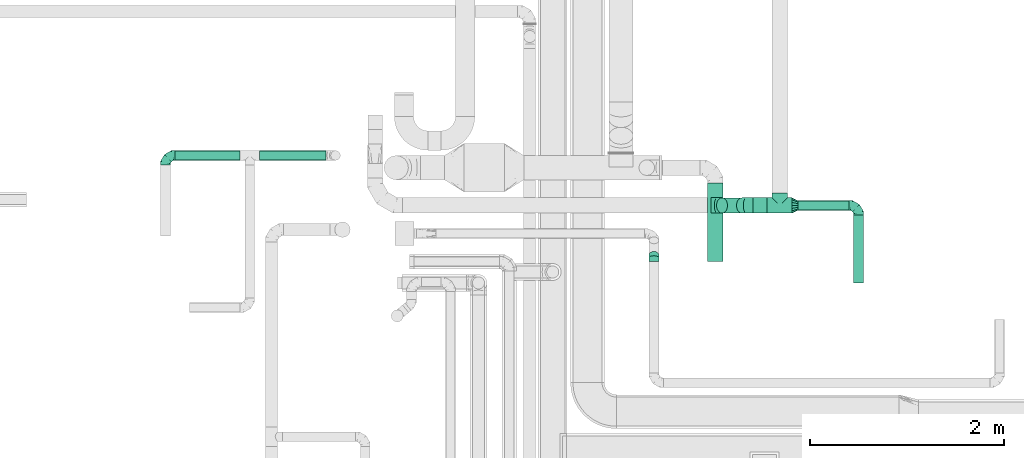
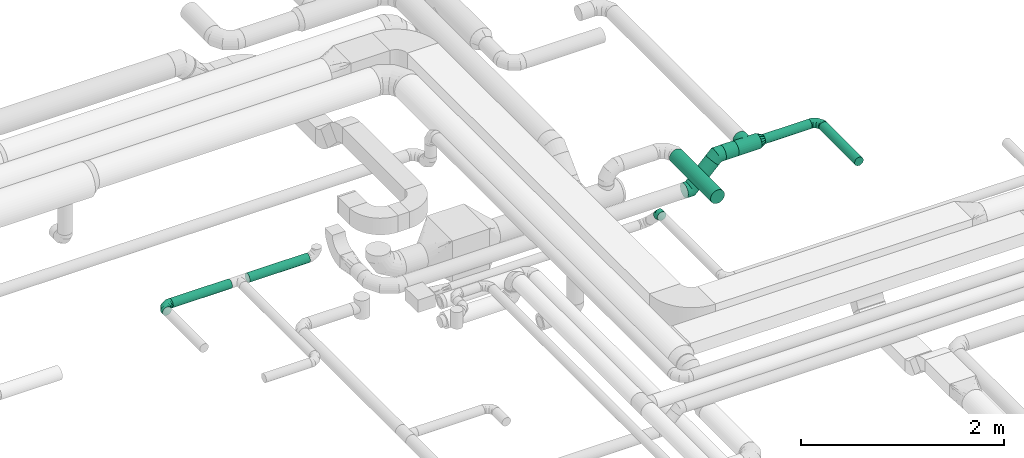
# One storey, part 69 of 92: 7 flow fittings, 7 flow segments.
"""IFC2X3 building model written with IfcOpenShell, lengths in millimetres."""

from ifc_helpers import new_model, entity, si_unit, converted_unit, derived_unit, direction, frame, origin, origin_2d_with_axis, place, context, subcontext, project, spatial, circle, extrude, faceted_brep, source, transform, mapped, material, type_object, type_shapes, element, save


model = new_model("IFC2X3")

# Units and contexts
model_context = context("Model", 3, precision=0.01, world=origin(), true_north=direction((6.12303176911189e-17, 1.0)))
body_context = subcontext(model_context, "Body", "Model", "MODEL_VIEW")
ifc_project = project(units=[si_unit("LENGTHUNIT", "METRE", prefix="MILLI"), si_unit("AREAUNIT", "SQUARE_METRE"), si_unit("VOLUMEUNIT", "CUBIC_METRE"), converted_unit("PLANEANGLEUNIT", "DEGREE", entity("IfcRatioMeasure", 0.0174532925199433), si_unit("PLANEANGLEUNIT", "RADIAN"), dimensions=[0, 0, 0, 0, 0, 0, 0]), si_unit("MASSUNIT", "GRAM", prefix="KILO"), derived_unit("MASSDENSITYUNIT", [(si_unit("MASSUNIT", "GRAM", prefix="KILO"), 1), (si_unit("LENGTHUNIT", "METRE"), -3)]), derived_unit("MOMENTOFINERTIAUNIT", [(si_unit("LENGTHUNIT", "METRE"), 4)]), si_unit("TIMEUNIT", "SECOND"), si_unit("FREQUENCYUNIT", "HERTZ"), si_unit("THERMODYNAMICTEMPERATUREUNIT", "DEGREE_CELSIUS"), derived_unit("THERMALTRANSMITTANCEUNIT", [(si_unit("MASSUNIT", "GRAM", prefix="KILO"), 1), (si_unit("THERMODYNAMICTEMPERATUREUNIT", "KELVIN"), -1), (si_unit("TIMEUNIT", "SECOND"), -3)]), derived_unit("VOLUMETRICFLOWRATEUNIT", [(si_unit("LENGTHUNIT", "METRE"), 3), (si_unit("TIMEUNIT", "SECOND"), -1)]), derived_unit("MASSFLOWRATEUNIT", [(si_unit("MASSUNIT", "GRAM", prefix="KILO"), 1), (si_unit("TIMEUNIT", "SECOND"), -1)]), derived_unit("ROTATIONALFREQUENCYUNIT", [(si_unit("TIMEUNIT", "SECOND"), -1)]), si_unit("ELECTRICCURRENTUNIT", "AMPERE"), si_unit("ELECTRICVOLTAGEUNIT", "VOLT"), si_unit("POWERUNIT", "WATT"), si_unit("FORCEUNIT", "NEWTON", prefix="KILO"), si_unit("ILLUMINANCEUNIT", "LUX"), si_unit("LUMINOUSFLUXUNIT", "LUMEN"), si_unit("LUMINOUSINTENSITYUNIT", "CANDELA"), derived_unit("USERDEFINED", [(si_unit("MASSUNIT", "GRAM", prefix="KILO"), -1), (si_unit("LENGTHUNIT", "METRE"), -2), (si_unit("TIMEUNIT", "SECOND"), 3), (si_unit("LUMINOUSFLUXUNIT", "LUMEN"), 1)]), derived_unit("LINEARVELOCITYUNIT", [(si_unit("LENGTHUNIT", "METRE"), 1), (si_unit("TIMEUNIT", "SECOND"), -1)]), si_unit("PRESSUREUNIT", "PASCAL"), derived_unit("USERDEFINED", [(si_unit("LENGTHUNIT", "METRE"), -2), (si_unit("MASSUNIT", "GRAM", prefix="KILO"), 1), (si_unit("TIMEUNIT", "SECOND"), -2)]), derived_unit("LINEARFORCEUNIT", [(si_unit("MASSUNIT", "GRAM", prefix="KILO"), 1), (si_unit("LENGTHUNIT", "METRE"), 1), (si_unit("TIMEUNIT", "SECOND"), -2), (si_unit("LENGTHUNIT", "METRE"), -1)]), derived_unit("PLANARFORCEUNIT", [(si_unit("MASSUNIT", "GRAM", prefix="KILO"), 1), (si_unit("LENGTHUNIT", "METRE"), 1), (si_unit("TIMEUNIT", "SECOND"), -2), (si_unit("LENGTHUNIT", "METRE"), -2)])], contexts=[model_context])

# Site, building, storey
site_placement = place(None, origin())
site = spatial("IfcSite", under=ifc_project, at=site_placement, CompositionType="ELEMENT")
building_placement = place(site_placement, origin())
building = spatial("IfcBuilding", under=site, at=building_placement, CompositionType="ELEMENT")
storey_placement = place(building_placement, frame((0.0, 0.0, 4200.0)))
storey = spatial("IfcBuildingStorey", under=building, at=storey_placement, CompositionType="ELEMENT", Elevation=4200.0)

# Flow segments
duct_segment_type_1 = type_object("IfcDuctSegmentType", PredefinedType="NOTDEFINED")
flow_segment_1_placement = place(storey_placement, frame((62682.47, 11524.89, 3228.4)))
element("IfcFlowSegment", 1, at=flow_segment_1_placement, inside=storey, type_object=duct_segment_type_1, context=body_context, shape_type="SweptSolid", body=[
    extrude(circle(Radius=80.0, at=origin_2d_with_axis()), frame((81.6, 0.0, 81.6), z_axis=(0.0, 1.0, 0.0), x_axis=(-1.0, 0.0, 0.0)), (0.0, 0.0, 1.0), 808.823581411163),
])
flow_segment_2_placement = place(storey_placement, frame((63151.97, 12022.01, 3268.4)))
element("IfcFlowSegment", 2, at=flow_segment_2_placement, inside=storey, type_object=duct_segment_type_1, context=body_context, shape_type="SweptSolid", body=[
    extrude(circle(Radius=80.0, at=origin_2d_with_axis()), frame((0.0, 81.6, 81.6), z_axis=(1.0, 0.0, 0.0), x_axis=(0.0, 1.0, 0.0)), (0.0, 0.0, 1.0), 144.445713220315),
])
flow_segment_3_placement = place(storey_placement, frame((62774.4, 12022.01, 3038.7)))
element("IfcFlowSegment", 3, at=flow_segment_3_placement, inside=storey, type_object=duct_segment_type_1, context=body_context, shape_type="SweptSolid", body=[
    extrude(circle(Radius=80.0, at=origin_2d_with_axis()), frame((58.16, 81.6, 58.16), z_axis=(0.707106781186546, 0.0, 0.707106781186549), x_axis=(0.0, -1.0, 0.0)), (0.0, 0.0, 1.0), 291.715728752526),
])
flow_segment_4_placement = place(storey_placement, frame((64190.6, 11303.61, 3298.4)))
element("IfcFlowSegment", 4, at=flow_segment_4_placement, inside=storey, type_object=duct_segment_type_1, context=body_context, shape_type="SweptSolid", body=[
    extrude(circle(Radius=50.0, at=origin_2d_with_axis()), frame((51.6, 0.0, 51.6), z_axis=(0.0, 1.0, 0.0), x_axis=(1.0, 0.0, 0.0)), (0.0, 0.0, 1.0), 700.000000000005),
])
flow_segment_5_placement = place(storey_placement, frame((63616.42, 12052.01, 3298.4)))
element("IfcFlowSegment", 5, at=flow_segment_5_placement, inside=storey, type_object=duct_segment_type_1, context=body_context, shape_type="SweptSolid", body=[
    extrude(circle(Radius=50.0, at=origin_2d_with_axis()), frame((0.0, 51.6, 51.6), z_axis=(1.0, 0.0, 0.0), x_axis=(0.0, -1.0, 0.0)), (0.0, 0.0, 1.0), 525.778056668222),
])
duct_segment_type_2 = type_object("IfcDuctSegmentType", PredefinedType="NOTDEFINED")
flow_segment_6_placement = place(storey_placement, frame((57187.56, 12568.13, 3268.4)))
element("IfcFlowSegment", 6, at=flow_segment_6_placement, inside=storey, type_object=duct_segment_type_2, context=body_context, shape_type="SweptSolid", body=[
    extrude(circle(Radius=50.0, at=origin_2d_with_axis()), frame((0.0, 51.6, 51.6), z_axis=(1.0, 0.0, 0.0), x_axis=(0.0, 1.0, 0.0)), (0.0, 0.0, 1.0), 670.999999999995),
])
flow_segment_7_placement = place(storey_placement, frame((58058.56, 12568.13, 3268.4)))
element("IfcFlowSegment", 7, at=flow_segment_7_placement, inside=storey, type_object=duct_segment_type_2, context=body_context, shape_type="SweptSolid", body=[
    extrude(circle(Radius=50.0, at=origin_2d_with_axis()), frame((0.0, 51.6, 51.6), z_axis=(1.0, 0.0, 0.0), x_axis=(0.0, 1.0, 0.0)), (0.0, 0.0, 1.0), 685.0),
])

# Flow fittings
ifc_material = material()
duct_fitting_type_1 = type_object("IfcDuctFittingType", PredefinedType="NOTDEFINED", material=ifc_material)
shared_shape_1 = source(origin(), body_context, "Body", "Brep", [
    faceted_brep([(-100.0, 0.0, -50.0), (-100.0, -12.94, -48.3), (-100.0, -25.0, -43.3), (-100.0, -35.36, -35.36), (-100.0, -43.3, -25.0), (-100.0, -48.3, -12.94), (-100.0, -50.0, 0.0), (-100.0, -48.3, 12.94), (-100.0, -43.3, 25.0), (-100.0, -35.36, 35.36), (-100.0, -25.0, 43.3), (-100.0, -12.94, 48.3), (-100.0, 0.0, 50.0), (-100.0, 12.94, 48.3), (-100.0, 25.0, 43.3), (-100.0, 35.36, 35.36), (-100.0, 43.3, 25.0), (-100.0, 48.3, 12.94), (-100.0, 50.0, 0.0), (-100.0, 48.3, -12.94), (-100.0, 43.3, -25.0), (-100.0, 35.36, -35.36), (-100.0, 25.0, -43.3), (-100.0, 12.94, -48.3), (-76.67, 12.94, 48.3), (-79.9, 25.0, 43.3), (-73.21, 0.0, 50.0), (-82.68, 35.36, 35.36), (-86.15, 48.3, 12.94), (-86.6, 50.0, 0.0), (-84.81, 43.3, 25.0), (-84.81, 43.3, -25.0), (-82.68, 35.36, -35.36), (-86.15, 48.3, -12.94), (-76.67, 12.94, -48.3), (-73.21, 0.0, -50.0), (-79.9, 25.0, -43.3), (-69.74, -12.94, -48.3), (-66.51, -25.0, -43.3), (-63.73, -35.36, -35.36), (-61.6, -43.3, -25.0), (-60.26, -48.3, -12.94), (-59.81, -50.0, 0.0), (-60.26, -48.3, 12.94), (-61.6, -43.3, 25.0), (-63.73, -35.36, 35.36), (-66.51, -25.0, 43.3), (-69.74, -12.94, 48.3), (-36.27, 36.27, 48.3), (-45.1, 45.1, 43.3), (-26.79, 26.79, 50.0), (-52.68, 52.68, 35.36), (-58.49, 58.49, 25.0), (-62.15, 62.15, 12.94), (-63.4, 63.4, 0.0), (-62.15, 62.15, -12.94), (-58.49, 58.49, -25.0), (-52.68, 52.68, -35.36), (-36.27, 36.27, -48.3), (-26.79, 26.79, -50.0), (-45.1, 45.1, -43.3), (-17.32, 17.32, -48.3), (-8.49, 8.49, -43.3), (-0.91, 0.91, -35.36), (4.9, -4.9, -25.0), (8.56, -8.56, -12.94), (9.81, -9.81, 0.0), (8.56, -8.56, 12.94), (4.9, -4.9, 25.0), (-0.91, 0.91, 35.36), (-8.49, 8.49, 43.3), (-17.32, 17.32, 48.3), (-12.94, 76.67, 48.3), (-25.0, 79.9, 43.3), (0.0, 73.21, 50.0), (-35.36, 82.68, 35.36), (-43.3, 84.81, 25.0), (-48.3, 86.15, 12.94), (-50.0, 86.6, 0.0), (-48.3, 86.15, -12.94), (-43.3, 84.81, -25.0), (-35.36, 82.68, -35.36), (-12.94, 76.67, -48.3), (0.0, 73.21, -50.0), (-25.0, 79.9, -43.3), (12.94, 69.74, -48.3), (25.0, 66.51, -43.3), (35.36, 63.73, -35.36), (43.3, 61.6, -25.0), (48.3, 60.26, -12.94), (50.0, 59.81, 0.0), (48.3, 60.26, 12.94), (43.3, 61.6, 25.0), (35.36, 63.73, 35.36), (25.0, 66.51, 43.3), (12.94, 69.74, 48.3), (-12.94, 100.0, -48.3), (-25.0, 100.0, -43.3), (-35.36, 100.0, -35.36), (-43.3, 100.0, -25.0), (-48.3, 100.0, -12.94), (-50.0, 100.0, 0.0), (-48.3, 100.0, 12.94), (-43.3, 100.0, 25.0), (-35.36, 100.0, 35.36), (-25.0, 100.0, 43.3), (-12.94, 100.0, 48.3), (0.0, 100.0, 50.0), (12.94, 100.0, 48.3), (25.0, 100.0, 43.3), (35.36, 100.0, 35.36), (43.3, 100.0, 25.0), (48.3, 100.0, 12.94), (50.0, 100.0, 0.0), (48.3, 100.0, -12.94), (43.3, 100.0, -25.0), (35.36, 100.0, -35.36), (25.0, 100.0, -43.3), (12.94, 100.0, -48.3), (0.0, 100.0, -50.0)], [[[0, 1, 2, 3, 4, 5, 6, 7, 8, 9, 10, 11, 12, 13, 14, 15, 16, 17, 18, 19, 20, 21, 22, 23]], [[24, 25, 14, 13]], [[26, 24, 13, 12]], [[14, 25, 27, 15]], [[28, 29, 18, 17]], [[30, 28, 17, 16]], [[15, 27, 30, 16]], [[20, 31, 32, 21]], [[33, 31, 20, 19]], [[18, 29, 33, 19]], [[34, 35, 0, 23]], [[36, 34, 23, 22]], [[32, 36, 22, 21]], [[2, 1, 37, 38]], [[3, 2, 38, 39]], [[0, 35, 37, 1]], [[5, 4, 40, 41]], [[6, 5, 41, 42]], [[3, 39, 40, 4]], [[6, 42, 43, 7]], [[7, 43, 44, 8]], [[8, 44, 45, 9]], [[10, 46, 47, 11]], [[11, 47, 26, 12]], [[10, 9, 45, 46]], [[48, 49, 25, 24]], [[50, 48, 24, 26]], [[27, 25, 49, 51]], [[52, 53, 28, 30]], [[51, 52, 30, 27]], [[29, 28, 53, 54]], [[55, 56, 31, 33]], [[54, 55, 33, 29]], [[57, 32, 31, 56]], [[58, 59, 35, 34]], [[60, 58, 34, 36]], [[57, 60, 36, 32]], [[37, 35, 59, 61]], [[38, 37, 61, 62]], [[39, 38, 62, 63]], [[41, 40, 64, 65]], [[42, 41, 65, 66]], [[63, 64, 40, 39]], [[43, 42, 66, 67]], [[44, 43, 67, 68]], [[68, 69, 45, 44]], [[46, 45, 69, 70]], [[47, 46, 70, 71]], [[26, 47, 71, 50]], [[72, 73, 49, 48]], [[74, 72, 48, 50]], [[51, 49, 73, 75]], [[76, 77, 53, 52]], [[75, 76, 52, 51]], [[54, 53, 77, 78]], [[79, 80, 56, 55]], [[78, 79, 55, 54]], [[81, 57, 56, 80]], [[82, 83, 59, 58]], [[84, 82, 58, 60]], [[81, 84, 60, 57]], [[61, 59, 83, 85]], [[62, 61, 85, 86]], [[63, 62, 86, 87]], [[65, 64, 88, 89]], [[66, 65, 89, 90]], [[87, 88, 64, 63]], [[67, 66, 90, 91]], [[68, 67, 91, 92]], [[92, 93, 69, 68]], [[70, 69, 93, 94]], [[71, 70, 94, 95]], [[50, 71, 95, 74]], [[96, 97, 98, 99, 100, 101, 102, 103, 104, 105, 106, 107, 108, 109, 110, 111, 112, 113, 114, 115, 116, 117, 118, 119]], [[72, 74, 107, 106]], [[73, 72, 106, 105]], [[75, 73, 105, 104]], [[77, 76, 103, 102]], [[78, 77, 102, 101]], [[75, 104, 103, 76]], [[78, 101, 100, 79]], [[79, 100, 99, 80]], [[80, 99, 98, 81]], [[96, 119, 83, 82]], [[97, 96, 82, 84]], [[84, 81, 98, 97]], [[83, 119, 118, 85]], [[85, 118, 117, 86]], [[86, 117, 116, 87]], [[88, 115, 114, 89]], [[89, 114, 113, 90]], [[87, 116, 115, 88]], [[91, 90, 113, 112]], [[92, 91, 112, 111]], [[93, 92, 111, 110]], [[95, 94, 109, 108]], [[74, 95, 108, 107]], [[110, 109, 94, 93]]]),
])
type_shapes(duct_fitting_type_1, [shared_shape_1])
for number, where, z_axis, x_axis in (
    (8, (57087.56, 12619.72, 3320.0), (0.0, 0.0, 1.0), (-1.0, 0.0, 0.0)),
    (9, (64242.2, 12103.61, 3350.0), (0.0, 0.0, 1.0), (0.0, 1.0, 0.0)),
):
    element("IfcFlowFitting", number, at=place(storey_placement, frame(where, z_axis=z_axis, x_axis=x_axis)), inside=storey, type_object=duct_fitting_type_1, material=ifc_material, context=body_context, shape_type="MappedRepresentation", body=[
        mapped(shared_shape_1, transform((0.0, 0.0, 0.0), scale=1.0)),
    ])
duct_fitting_type_2 = type_object("IfcDuctFittingType", PredefinedType="NOTDEFINED", material=ifc_material)
shared_shape_2 = source(origin(), body_context, "Body", "Brep", [
    faceted_brep([(60.0, -46.19, 19.13), (60.0, -48.1, 9.57), (60.0, -50.0, 0.0), (60.0, -48.1, -9.57), (60.0, -46.19, -19.13), (60.0, -40.77, -27.24), (60.0, -35.36, -35.36), (60.0, -27.24, -40.77), (60.0, -19.13, -46.19), (60.0, -9.57, -48.1), (60.0, 0.0, -50.0), (60.0, 9.57, -48.1), (60.0, 19.13, -46.19), (60.0, 27.24, -40.77), (60.0, 35.36, -35.36), (60.0, 40.77, -27.24), (60.0, 46.19, -19.13), (60.0, 48.1, -9.57), (60.0, 50.0, 0.0), (60.0, 48.1, 9.57), (60.0, 46.19, 19.13), (60.0, 40.77, 27.24), (60.0, 35.36, 35.36), (60.0, 27.24, 40.77), (60.0, 19.13, 46.19), (60.0, 9.57, 48.1), (60.0, 0.0, 50.0), (60.0, -9.57, 48.1), (60.0, -19.13, 46.19), (60.0, -27.24, 40.77), (60.0, -35.36, 35.36), (60.0, -40.77, 27.24), (0.0, -80.0, 0.0), (0.0, -77.16, 14.27), (0.0, -73.91, 30.61), (0.0, -65.24, 43.59), (0.0, -56.57, 56.57), (0.0, -43.59, 65.24), (0.0, -30.61, 73.91), (0.0, -15.31, 76.96), (0.0, 0.0, 80.0), (0.0, 14.27, 77.16), (0.0, 30.61, 73.91), (0.0, 43.59, 65.24), (0.0, 56.57, 56.57), (0.0, 65.24, 43.59), (0.0, 73.91, 30.61), (0.0, 76.96, 15.31), (0.0, 80.0, 0.0), (0.0, 77.16, -14.27), (0.0, 73.91, -30.61), (0.0, 65.24, -43.59), (0.0, 56.57, -56.57), (0.0, 43.59, -65.24), (0.0, 30.61, -73.91), (0.0, 15.31, -76.96), (0.0, 0.0, -80.0), (0.0, -14.27, -77.16), (0.0, -30.61, -73.91), (0.0, -43.59, -65.24), (0.0, -56.57, -56.57), (0.0, -65.24, -43.59), (0.0, -73.91, -30.61), (0.0, -76.96, -15.31)], [[[0, 1, 2, 3, 4, 5, 6, 7, 8, 9, 10, 11, 12, 13, 14, 15, 16, 17, 18, 19, 20, 21, 22, 23, 24, 25, 26, 27, 28, 29, 30, 31]], [[32, 33, 34, 35, 36, 37, 38, 39, 40, 41, 42, 43, 44, 45, 46, 47, 48, 49, 50, 51, 52, 53, 54, 55, 56, 57, 58, 59, 60, 61, 62, 63]], [[42, 41, 40, 26, 25, 24]], [[43, 42, 24, 23, 22, 44]], [[20, 46, 45, 44, 22, 21]], [[18, 48, 47, 46, 20, 19]], [[34, 33, 32, 2, 1, 0]], [[35, 34, 0, 31, 30, 36]], [[28, 38, 37, 36, 30, 29]], [[26, 40, 39, 38, 28, 27]], [[58, 57, 56, 10, 9, 8]], [[59, 58, 8, 7, 6, 60]], [[4, 62, 61, 60, 6, 5]], [[2, 32, 63, 62, 4, 3]], [[50, 49, 48, 18, 17, 16]], [[51, 50, 16, 15, 14, 52]], [[12, 54, 53, 52, 14, 13]], [[10, 56, 55, 54, 12, 11]]]),
])
type_shapes(duct_fitting_type_2, [shared_shape_2])
flow_fitting_1_placement = place(storey_placement, frame((63556.42, 12103.61, 3350.0)))
element("IfcFlowFitting", 10, at=flow_fitting_1_placement, inside=storey, type_object=duct_fitting_type_2, material=ifc_material, context=body_context, shape_type="MappedRepresentation", body=[
    mapped(shared_shape_2, transform((0.0, 0.0, 0.0), scale=1.0)),
])
duct_fitting_type_3 = type_object("IfcDuctFittingType", PredefinedType="NOTDEFINED", material=ifc_material)
shared_shape_3 = source(origin(), body_context, "Body", "Brep", [
    faceted_brep([(-66.27, 0.0, -80.0), (-66.27, -20.71, -77.27), (-66.27, -40.0, -69.28), (-66.27, -56.57, -56.57), (-66.27, -69.28, -40.0), (-66.27, -77.27, -20.71), (-66.27, -80.0, 0.0), (-66.27, -77.27, 20.71), (-66.27, -69.28, 40.0), (-66.27, -56.57, 56.57), (-66.27, -40.0, 69.28), (-66.27, -20.71, 77.27), (-66.27, 0.0, 80.0), (-66.27, 20.71, 77.27), (-66.27, 40.0, 69.28), (-66.27, 56.57, 56.57), (-66.27, 69.28, 40.0), (-66.27, 77.27, 20.71), (-66.27, 80.0, 0.0), (-66.27, 77.27, -20.71), (-66.27, 69.28, -40.0), (-66.27, 56.57, -56.57), (-66.27, 40.0, -69.28), (-66.27, 20.71, -77.27), (-8.58, 20.71, 77.27), (-16.57, 40.0, 69.28), (0.0, 0.0, 80.0), (-23.43, 56.57, 56.57), (-28.7, 69.28, 40.0), (-32.01, 77.27, 20.71), (-33.14, 80.0, 0.0), (-32.01, 77.27, -20.71), (-28.7, 69.28, -40.0), (-23.43, 56.57, -56.57), (-8.58, 20.71, -77.27), (0.0, 0.0, -80.0), (-16.57, 40.0, -69.28), (8.58, -20.71, -77.27), (16.57, -40.0, -69.28), (23.43, -56.57, -56.57), (28.7, -69.28, -40.0), (32.01, -77.27, -20.71), (33.14, -80.0, 0.0), (32.01, -77.27, 20.71), (28.7, -69.28, 40.0), (23.43, -56.57, 56.57), (16.57, -40.0, 69.28), (8.58, -20.71, 77.27), (46.86, 46.86, 80.0), (32.22, 61.5, 77.27), (18.58, 75.15, 69.28), (6.86, 86.86, 56.57), (-2.13, 95.85, 40.0), (-7.78, 101.5, 20.71), (-9.71, 103.43, 0.0), (-7.78, 101.5, -20.71), (-2.13, 95.85, -40.0), (6.86, 86.86, -56.57), (18.58, 75.15, -69.28), (32.22, 61.5, -77.27), (46.86, 46.86, -80.0), (61.5, 32.22, -77.27), (75.15, 18.58, -69.28), (86.86, 6.86, -56.57), (95.85, -2.13, -40.0), (101.5, -7.78, -20.71), (103.43, -9.71, 0.0), (101.5, -7.78, 20.71), (95.85, -2.13, 40.0), (86.86, 6.86, 56.57), (75.15, 18.58, 69.28), (61.5, 32.22, 77.27)], [[[0, 1, 2, 3, 4, 5, 6, 7, 8, 9, 10, 11, 12, 13, 14, 15, 16, 17, 18, 19, 20, 21, 22, 23]], [[24, 25, 14, 13]], [[26, 24, 13, 12]], [[14, 25, 27, 15]], [[28, 29, 17, 16]], [[28, 16, 15, 27]], [[30, 18, 17, 29]], [[31, 32, 20, 19]], [[30, 31, 19, 18]], [[32, 33, 21, 20]], [[34, 35, 0, 23]], [[36, 34, 23, 22]], [[33, 36, 22, 21]], [[1, 0, 35, 37]], [[2, 1, 37, 38]], [[38, 39, 3, 2]], [[5, 4, 40, 41]], [[6, 5, 41, 42]], [[39, 40, 4, 3]], [[6, 42, 43, 7]], [[7, 43, 44, 8]], [[8, 44, 45, 9]], [[9, 45, 46, 10]], [[10, 46, 47, 11]], [[26, 12, 11, 47]], [[24, 26, 48, 49]], [[25, 24, 49, 50]], [[27, 25, 50, 51]], [[29, 28, 52, 53]], [[30, 29, 53, 54]], [[51, 52, 28, 27]], [[30, 54, 55, 31]], [[31, 55, 56, 32]], [[57, 33, 32, 56]], [[36, 58, 59, 34]], [[34, 59, 60, 35]], [[58, 36, 33, 57]], [[35, 60, 61, 37]], [[37, 61, 62, 38]], [[63, 39, 38, 62]], [[40, 64, 65, 41]], [[41, 65, 66, 42]], [[64, 40, 39, 63]], [[43, 42, 66, 67]], [[44, 43, 67, 68]], [[68, 69, 45, 44]], [[47, 46, 70, 71]], [[26, 47, 71, 48]], [[69, 70, 46, 45]], [[59, 58, 57, 56, 55, 54, 53, 52, 51, 50, 49, 48, 71, 70, 69, 68, 67, 66, 65, 64, 63, 62, 61, 60]]]),
])
type_shapes(duct_fitting_type_3, [shared_shape_3])
for number, where, z_axis, x_axis in (
    (11, (63085.7, 12103.61, 3350.0), (0.0, -1.0, 0.0), (-1.0, 0.0, 0.0)),
    (12, (62785.7, 12103.61, 3050.0), (0.0, 1.0, 0.0), (-0.707106781186524, 0.0, -0.707106781186572)),
):
    element("IfcFlowFitting", number, at=place(storey_placement, frame(where, z_axis=z_axis, x_axis=x_axis)), inside=storey, type_object=duct_fitting_type_3, material=ifc_material, context=body_context, shape_type="MappedRepresentation", body=[
        mapped(shared_shape_3, transform((0.0, 0.0, 0.0), scale=1.0)),
    ])
duct_fitting_type_4 = type_object("IfcDuctFittingType", PredefinedType="NOTDEFINED", material=ifc_material)
shared_shape_4 = source(origin(), body_context, "Body", "Brep", [
    faceted_brep([(-41.42, 0.0, -50.0), (-41.42, -12.94, -48.3), (-41.42, -25.0, -43.3), (-41.42, -35.36, -35.36), (-41.42, -43.3, -25.0), (-41.42, -48.3, -12.94), (-41.42, -50.0, 0.0), (-41.42, -48.3, 12.94), (-41.42, -43.3, 25.0), (-41.42, -35.36, 35.36), (-41.42, -25.0, 43.3), (-41.42, -12.94, 48.3), (-41.42, 0.0, 50.0), (-41.42, 12.94, 48.3), (-41.42, 25.0, 43.3), (-41.42, 35.36, 35.36), (-41.42, 43.3, 25.0), (-41.42, 48.3, 12.94), (-41.42, 50.0, 0.0), (-41.42, 48.3, -12.94), (-41.42, 43.3, -25.0), (-41.42, 35.36, -35.36), (-41.42, 25.0, -43.3), (-41.42, 12.94, -48.3), (-5.36, 12.94, 48.3), (-10.36, 25.0, 43.3), (0.0, 0.0, 50.0), (-14.64, 35.36, 35.36), (-20.0, 48.3, 12.94), (-20.71, 50.0, 0.0), (-17.94, 43.3, 25.0), (-17.94, 43.3, -25.0), (-14.64, 35.36, -35.36), (-20.0, 48.3, -12.94), (-5.36, 12.94, -48.3), (0.0, 0.0, -50.0), (-10.36, 25.0, -43.3), (5.36, -12.94, -48.3), (10.36, -25.0, -43.3), (14.64, -35.36, -35.36), (17.94, -43.3, -25.0), (20.0, -48.3, -12.94), (20.71, -50.0, 0.0), (20.0, -48.3, 12.94), (17.94, -43.3, 25.0), (14.64, -35.36, 35.36), (10.36, -25.0, 43.3), (5.36, -12.94, 48.3), (29.29, 29.29, 50.0), (20.14, 38.44, 48.3), (11.61, 46.97, 43.3), (4.29, 54.29, 35.36), (-1.33, 59.91, 25.0), (-4.86, 63.44, 12.94), (-6.07, 64.64, 0.0), (-4.86, 63.44, -12.94), (-1.33, 59.91, -25.0), (4.29, 54.29, -35.36), (11.61, 46.97, -43.3), (20.14, 38.44, -48.3), (29.29, 29.29, -50.0), (38.44, 20.14, -48.3), (46.97, 11.61, -43.3), (54.29, 4.29, -35.36), (59.91, -1.33, -25.0), (63.44, -4.86, -12.94), (64.64, -6.07, 0.0), (63.44, -4.86, 12.94), (59.91, -1.33, 25.0), (54.29, 4.29, 35.36), (46.97, 11.61, 43.3), (38.44, 20.14, 48.3)], [[[0, 1, 2, 3, 4, 5, 6, 7, 8, 9, 10, 11, 12, 13, 14, 15, 16, 17, 18, 19, 20, 21, 22, 23]], [[24, 25, 14, 13]], [[26, 24, 13, 12]], [[14, 25, 27, 15]], [[28, 29, 18, 17]], [[30, 28, 17, 16]], [[16, 15, 27, 30]], [[20, 31, 32, 21]], [[33, 31, 20, 19]], [[18, 29, 33, 19]], [[34, 35, 0, 23]], [[36, 34, 23, 22]], [[32, 36, 22, 21]], [[1, 0, 35, 37]], [[2, 1, 37, 38]], [[38, 39, 3, 2]], [[5, 4, 40, 41]], [[6, 5, 41, 42]], [[39, 40, 4, 3]], [[6, 42, 43, 7]], [[7, 43, 44, 8]], [[8, 44, 45, 9]], [[9, 45, 46, 10]], [[10, 46, 47, 11]], [[26, 12, 11, 47]], [[24, 26, 48, 49]], [[25, 24, 49, 50]], [[27, 25, 50, 51]], [[28, 30, 52, 53]], [[29, 28, 53, 54]], [[27, 51, 52, 30]], [[29, 54, 55, 33]], [[33, 55, 56, 31]], [[31, 56, 57, 32]], [[36, 58, 59, 34]], [[34, 59, 60, 35]], [[36, 32, 57, 58]], [[61, 62, 38, 37]], [[60, 61, 37, 35]], [[63, 39, 38, 62]], [[40, 64, 65, 41]], [[41, 65, 66, 42]], [[64, 40, 39, 63]], [[43, 42, 66, 67]], [[44, 43, 67, 68]], [[68, 69, 45, 44]], [[47, 46, 70, 71]], [[26, 47, 71, 48]], [[69, 70, 46, 45]], [[59, 58, 57, 56, 55, 54, 53, 52, 51, 50, 49, 48, 71, 70, 69, 68, 67, 66, 65, 64, 63, 62, 61, 60]]]),
])
type_shapes(duct_fitting_type_4, [shared_shape_4])
flow_fitting_2_placement = place(storey_placement, frame((62130.0, 11564.2, 3300.0), z_axis=(1.0, 0.0, 0.0), x_axis=(0.0, -0.707106781186565, 0.70710678118653)))
element("IfcFlowFitting", 13, at=flow_fitting_2_placement, inside=storey, type_object=duct_fitting_type_4, material=ifc_material, context=body_context, shape_type="MappedRepresentation", body=[
    mapped(shared_shape_4, transform((0.0, 0.0, 0.0), scale=1.0)),
])
duct_fitting_type_5 = type_object("IfcDuctFittingType", PredefinedType="NOTDEFINED", material=ifc_material)
shared_shape_5 = source(origin(), body_context, "Body", "Brep", [
    faceted_brep([(11.97, -11.97, -79.1), (130.0, 0.0, -80.0), (130.0, -20.71, -77.27), (130.0, -40.0, -69.28), (35.34, -35.34, -71.77), (46.39, -46.39, -65.17), (130.0, -56.57, -56.57), (0.0, 0.0, -80.0), (-11.97, -11.97, -79.1), (-130.0, 0.0, -80.0), (23.81, -23.81, -76.38), (65.82, -65.82, -45.47), (130.0, -69.28, -40.0), (73.25, -73.25, -32.16), (130.0, -77.27, -20.71), (78.23, -78.23, -16.74), (130.0, -80.0, 0.0), (56.68, -56.68, -56.46), (80.0, -80.0, 0.0), (-130.0, -80.0, 0.0), (-78.23, -78.23, -16.74), (-80.0, -80.0, 0.0), (78.23, -78.23, 16.74), (-78.23, -78.23, 16.74), (130.0, -77.27, 20.71), (73.25, -73.25, 32.16), (130.0, -69.28, 40.0), (130.0, -56.57, 56.57), (56.68, -56.68, 56.46), (65.82, -65.82, 45.47), (46.39, -46.39, 65.17), (130.0, -40.0, 69.28), (35.34, -35.34, 71.77), (130.0, -20.71, 77.27), (11.97, -11.97, 79.1), (130.0, 0.0, 80.0), (23.81, -23.81, 76.38), (0.0, 0.0, 80.0), (-11.97, -11.97, 79.1), (-130.0, 0.0, 80.0), (20.71, -130.0, -77.27), (40.0, -130.0, -69.28), (56.57, -130.0, -56.57), (69.28, -130.0, -40.0), (77.27, -130.0, -20.71), (80.0, -130.0, 0.0), (77.27, -130.0, 20.71), (69.28, -130.0, 40.0), (56.57, -130.0, 56.57), (40.0, -130.0, 69.28), (20.71, -130.0, 77.27), (0.0, -130.0, 80.0), (-20.71, -130.0, 77.27), (-40.0, -130.0, 69.28), (-56.57, -130.0, 56.57), (-69.28, -130.0, 40.0), (-77.27, -130.0, 20.71), (-80.0, -130.0, 0.0), (-77.27, -130.0, -20.71), (-69.28, -130.0, -40.0), (-56.57, -130.0, -56.57), (-40.0, -130.0, -69.28), (-20.71, -130.0, -77.27), (0.0, -130.0, -80.0), (-35.34, -35.34, -71.77), (-46.39, -46.39, -65.17), (-23.81, -23.81, -76.38), (-65.82, -65.82, -45.47), (-73.25, -73.25, -32.16), (-56.68, -56.68, -56.46), (-73.25, -73.25, 32.16), (-56.68, -56.68, 56.46), (-65.82, -65.82, 45.47), (-46.39, -46.39, 65.17), (-35.34, -35.34, 71.77), (-23.81, -23.81, 76.38), (-130.0, -20.71, -77.27), (-130.0, -40.0, -69.28), (-130.0, -56.57, -56.57), (-130.0, -69.28, -40.0), (-130.0, -77.27, -20.71), (-130.0, -77.27, 20.71), (-130.0, -69.28, 40.0), (-130.0, -56.57, 56.57), (-130.0, -40.0, 69.28), (-130.0, -20.71, 77.27), (-130.0, 20.71, 77.27), (-130.0, 40.0, 69.28), (-130.0, 56.57, 56.57), (-130.0, 69.28, 40.0), (-130.0, 77.27, 20.71), (-130.0, 80.0, 0.0), (-130.0, 77.27, -20.71), (-130.0, 69.28, -40.0), (-130.0, 56.57, -56.57), (-130.0, 40.0, -69.28), (-130.0, 20.71, -77.27), (130.0, 20.71, -77.27), (130.0, 40.0, -69.28), (130.0, 56.57, -56.57), (130.0, 69.28, -40.0), (130.0, 77.27, -20.71), (130.0, 80.0, 0.0), (130.0, 77.27, 20.71), (130.0, 69.28, 40.0), (130.0, 56.57, 56.57), (130.0, 40.0, 69.28), (130.0, 20.71, 77.27)], [[[0, 1, 2]], [[2, 3, 4]], [[5, 3, 6]], [[5, 4, 3]], [[0, 7, 1]], [[7, 8, 9]], [[4, 10, 2]], [[0, 2, 10]], [[11, 6, 12]], [[13, 12, 14]], [[15, 14, 16]], [[11, 17, 6]], [[15, 13, 14]], [[18, 15, 16]], [[19, 20, 21]], [[11, 12, 13]], [[6, 17, 5]], [[22, 18, 16]], [[21, 23, 19]], [[22, 16, 24]], [[25, 24, 26]], [[25, 22, 24]], [[27, 28, 29]], [[25, 26, 29]], [[29, 26, 27]], [[30, 27, 31]], [[32, 31, 33]], [[34, 33, 35]], [[32, 30, 31]], [[34, 36, 33]], [[37, 34, 35]], [[38, 37, 39]], [[32, 33, 36]], [[27, 30, 28]], [[40, 41, 42, 43, 44, 45, 46, 47, 48, 49, 50, 51, 52, 53, 54, 55, 56, 57, 58, 59, 60, 61, 62, 63]], [[34, 51, 50]], [[50, 49, 32]], [[30, 49, 48]], [[30, 32, 49]], [[34, 37, 51]], [[32, 36, 50]], [[34, 50, 36]], [[29, 48, 47]], [[25, 47, 46]], [[22, 46, 45]], [[29, 28, 48]], [[22, 25, 46]], [[18, 22, 45]], [[29, 47, 25]], [[48, 28, 30]], [[15, 18, 45]], [[15, 45, 44]], [[13, 44, 43]], [[13, 15, 44]], [[42, 17, 11]], [[13, 43, 11]], [[11, 43, 42]], [[5, 42, 41]], [[4, 41, 40]], [[0, 40, 63]], [[4, 5, 41]], [[0, 10, 40]], [[7, 0, 63]], [[4, 40, 10]], [[42, 5, 17]], [[8, 63, 62]], [[62, 61, 64]], [[65, 61, 60]], [[65, 64, 61]], [[8, 7, 63]], [[64, 66, 62]], [[8, 62, 66]], [[67, 60, 59]], [[68, 59, 58]], [[20, 58, 57]], [[67, 69, 60]], [[20, 68, 58]], [[21, 20, 57]], [[67, 59, 68]], [[60, 69, 65]], [[23, 21, 57]], [[23, 57, 56]], [[70, 56, 55]], [[70, 23, 56]], [[54, 71, 72]], [[70, 55, 72]], [[72, 55, 54]], [[73, 54, 53]], [[74, 53, 52]], [[38, 52, 51]], [[74, 73, 53]], [[38, 75, 52]], [[37, 38, 51]], [[74, 52, 75]], [[54, 73, 71]], [[9, 76, 77, 78, 79, 80, 19, 81, 82, 83, 84, 85, 39, 86, 87, 88, 89, 90, 91, 92, 93, 94, 95, 96]], [[97, 98, 99, 100, 101, 102, 103, 104, 105, 106, 107, 35, 33, 31, 27, 26, 24, 16, 14, 12, 6, 3, 2, 1]], [[37, 35, 107, 86, 39]], [[87, 86, 107, 106]], [[106, 105, 88, 87]], [[89, 88, 105, 104]], [[90, 89, 104, 103]], [[91, 90, 103, 102]], [[92, 91, 102, 101]], [[93, 92, 101, 100]], [[100, 99, 94, 93]], [[95, 94, 99, 98]], [[96, 95, 98, 97]], [[7, 9, 96, 97, 1]], [[66, 64, 76]], [[8, 66, 76]], [[9, 8, 76]], [[77, 65, 78]], [[77, 76, 64]], [[65, 77, 64]], [[69, 67, 78]], [[68, 20, 80]], [[67, 68, 79]], [[78, 67, 79]], [[20, 19, 80]], [[80, 79, 68]], [[69, 78, 65]], [[23, 70, 81]], [[82, 72, 83]], [[70, 72, 82]], [[19, 23, 81]], [[70, 82, 81]], [[72, 71, 83]], [[74, 75, 85]], [[75, 38, 85]], [[83, 73, 84]], [[73, 83, 71]], [[74, 84, 73]], [[74, 85, 84]], [[38, 39, 85]]]),
])
type_shapes(duct_fitting_type_5, [shared_shape_5])
flow_fitting_3_placement = place(storey_placement, frame((63426.42, 12103.61, 3350.0), z_axis=(0.0, 0.0, 1.0), x_axis=(-1.0, 0.0, 0.0)))
element("IfcFlowFitting", 14, at=flow_fitting_3_placement, inside=storey, type_object=duct_fitting_type_5, material=ifc_material, context=body_context, shape_type="MappedRepresentation", body=[
    mapped(shared_shape_5, transform((0.0, 0.0, 0.0), scale=1.0)),
])

save(model, "model.ifc")
